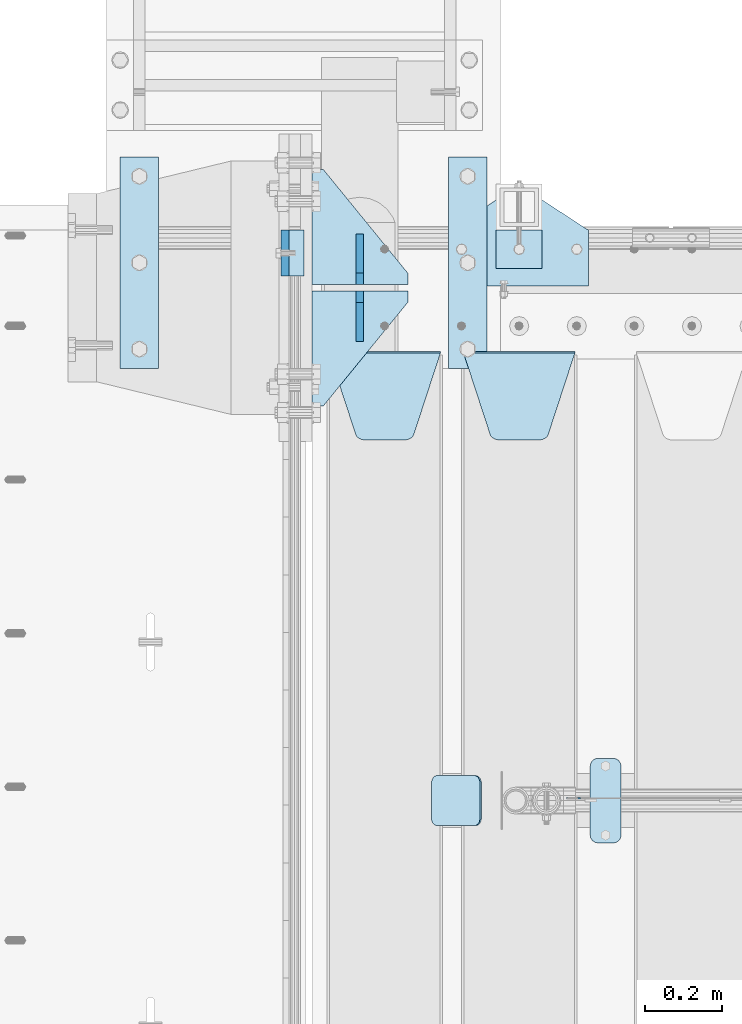
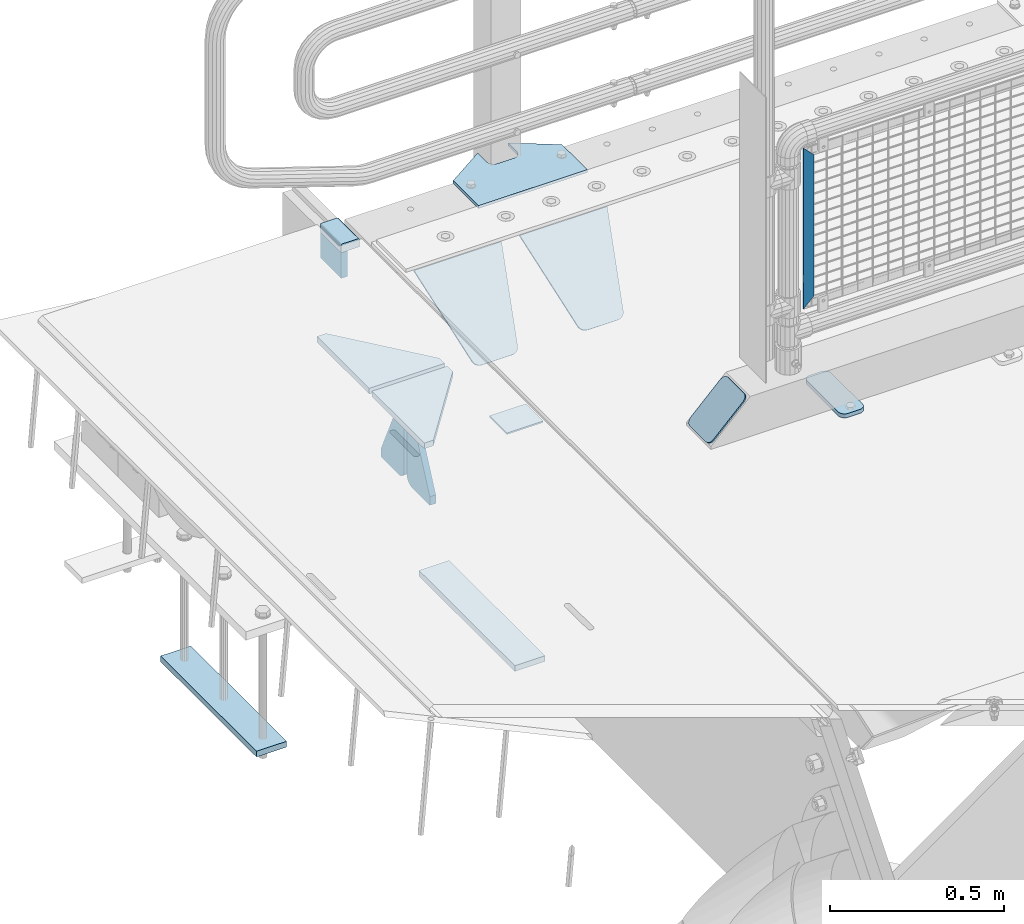
# One storey, part 229 of 270: 15 plates.
"""IFC2X3 building model written with IfcOpenShell, lengths in millimetres."""

from ifc_helpers import new_model, si_unit, frame, origin_with_axes, place, context, subcontext, project, spatial, faceted_brep, material, type_object, element, save


model = new_model("IFC2X3")

# Units and contexts
model_context = context("Model", 3, precision=1e-05, world=origin_with_axes())
body_context = subcontext(model_context, "Body", "Model", "MODEL_VIEW")
ifc_project = project(units=[si_unit("LENGTHUNIT", "METRE", prefix="MILLI"), si_unit("AREAUNIT", "SQUARE_METRE"), si_unit("VOLUMEUNIT", "CUBIC_METRE"), si_unit("MASSUNIT", "GRAM", prefix="KILO"), si_unit("TIMEUNIT", "SECOND"), si_unit("PLANEANGLEUNIT", "RADIAN"), si_unit("SOLIDANGLEUNIT", "STERADIAN"), si_unit("THERMODYNAMICTEMPERATUREUNIT", "DEGREE_CELSIUS"), si_unit("LUMINOUSINTENSITYUNIT", "LUMEN")], contexts=[model_context])

# Site, building, storey
site_placement = place(None, origin_with_axes())
site = spatial("IfcSite", under=ifc_project, at=site_placement, CompositionType="ELEMENT")
building_placement = place(site_placement, origin_with_axes())
building = spatial("IfcBuilding", under=site, at=building_placement, Name="Standard", CompositionType="ELEMENT")
storey_placement = place(building_placement, origin_with_axes())
storey = spatial("IfcBuildingStorey", under=building, at=storey_placement, Name="Undefined", CompositionType="ELEMENT", Elevation=0.0)

# Plates
ifc_material_1 = material()
plate_type_1 = type_object("IfcPlateType", PredefinedType="NOTDEFINED")
plate_1_placement = place(storey_placement, frame((-9.99999999999636, -14910.0, -16.0000571412578), z_axis=(-1.0, 0.0, 0.0), x_axis=(0.0, 0.0, 1.0)))
element("IfcPlate", 1, at=plate_1_placement, inside=storey, type_object=plate_type_1, material=ifc_material_1, context=body_context, shape_type="Brep", body=[
    faceted_brep([(1.77635683940025e-15, -60.0000000000073, 0.0), (2.49929321682885e-09, -60.0000000000073, 60.0), (2.49928966411517e-09, 59.9999999999964, 60.0), (-1.77635683940025e-15, 59.9999999999964, 0.0), (25.0146748218828, -60.0000000000073, 60.0), (25.0146748218828, 59.9999999999927, 60.0), (26.5597449794466, -60.0000000000073, 59.7552873949117), (26.5597449794466, 59.9999999999964, 59.7552873949117), (27.9535758796897, -60.0000000000036, 59.0451032832824), (27.9535758796897, 59.9999999999964, 59.0451032832824), (29.0597323263517, -60.0000000000073, 57.9389640667317), (29.0597323263517, 59.9999999999927, 57.9389640667317), (29.7699381491534, -60.0000000000036, 56.5451442289687), (29.7699381491534, 59.9999999999927, 56.5451442289687), (30.0146748212763, -60.0000000000073, 55.0000778834025), (30.0146748212762, 59.9999999999927, 55.0000778834025), (30.0154536553013, -60.0000000000036, 5.00007788340855), (30.0154536553013, 59.9999999999964, 5.00007788340855), (29.7707554908505, -60.0000000000073, 3.45497428546548), (29.7707554908505, 59.9999999999927, 3.45497428546548), (29.0605660948355, -60.0000000000073, 2.06111154407017), (29.0605660948355, 59.9999999999927, 2.06111154407017), (27.9544051209123, -60.0000000000036, 0.954933339696428), (27.9544051209123, 59.9999999999964, 0.954933339696428), (26.5605534420796, -60.0000000000036, 0.244722232012666), (26.5605534420796, 59.9999999999964, 0.244722232012666), (25.0154536559091, -60.0000000000073, 6.05382410867605e-12), (25.0154536559091, 59.9999999999927, 6.05382410867605e-12)], [[[0, 1, 2, 3]], [[1, 4, 5, 2]], [[4, 6, 7, 5]], [[6, 8, 9, 7]], [[8, 10, 11, 9]], [[10, 12, 13, 11]], [[12, 14, 15, 13]], [[14, 16, 17, 15]], [[16, 18, 19, 17]], [[18, 20, 21, 19]], [[20, 22, 23, 21]], [[22, 24, 25, 23]], [[24, 26, 27, 25]], [[26, 0, 3, 27]], [[5, 7, 9, 11, 13, 15, 17, 19, 21, 23, 25, 27, 3, 2]], [[26, 24, 22, 20, 18, 16, 14, 12, 10, 8, 6, 4, 1, 0]]]),
])
ifc_material_2 = material(Name="STEEL/S355N")
plate_type_2 = type_object("IfcPlateType", PredefinedType="NOTDEFINED")
plate_2_placement = place(storey_placement, frame((-60.0, -14849.9999144655, -105.984391681369), z_axis=(0.0, -1.0, 0.0), x_axis=(0.0, 0.0, 1.0)))
element("IfcPlate", 2, at=plate_2_placement, inside=storey, type_object=plate_type_2, material=ifc_material_2, context=body_context, shape_type="Brep", body=[
    faceted_brep([(0.0, -10.0, 0.0), (4.30830482400779e-10, -10.0, 120.000000000004), (4.30830482400779e-10, 10.0, 120.000000000004), (0.0, 10.0, 0.0), (89.9845046997066, -10.0, 120.0), (89.9845046997066, 10.0, 120.0), (89.9843902587891, -10.0, 6.54836185276508e-11), (89.9843902587891, 10.0, 6.54836185276508e-11)], [[[0, 1, 2, 3]], [[1, 4, 5, 2]], [[4, 6, 7, 5]], [[6, 0, 3, 7]], [[5, 7, 3, 2]], [[6, 4, 1, 0]]]),
])
plate_type_3 = type_object("IfcPlateType", PredefinedType="NOTDEFINED")
for number, where, z_axis, x_axis in (
    (3, (-488.999999999984, -14660.0000007156, -1478.0), (0.0, -1.0, 0.0), (1.0, 0.0, 0.0)),
    (4, (366.000000000016, -14659.9999998606, -1478.0), (0.0, -1.0, 0.0), (1.0, 0.0, 0.0)),
):
    element("IfcPlate", number, at=place(storey_placement, frame(where, z_axis=z_axis, x_axis=x_axis)), inside=storey, type_object=plate_type_3, material=ifc_material_2, context=body_context, shape_type="Brep", body=[
        faceted_brep([(0.0, -10.0, 0.0), (1.00943600500614e-06, -10.0, 550.0), (1.00943600500614e-06, 10.0, 550.0), (0.0, 10.0, 0.0), (100.000000000004, -10.0, 550.0), (100.000000000004, 10.0, 550.0), (100.0, -10.0, 0.0), (100.0, 10.0, 0.0)], [[[0, 1, 2, 3]], [[1, 4, 5, 2]], [[4, 6, 7, 5]], [[6, 0, 3, 7]], [[5, 7, 3, 2]], [[6, 4, 1, 0]]]),
    ])
ifc_material_3 = material(Name="STEEL/S355J2")
plate_type_4 = type_object("IfcPlateType", PredefinedType="NOTDEFINED")
plate_3_placement = place(storey_placement, frame((370.0, -14995.0, 5.00000000004911), z_axis=(0.0, 1.0, 0.0), x_axis=(1.0, 0.0, 0.0)))
element("IfcPlate", 5, at=plate_3_placement, inside=storey, type_object=plate_type_4, material=ifc_material_3, context=body_context, shape_type="Brep", body=[
    faceted_brep([(0.0, -5.0, 0.0), (2.31396552408114e-06, -5.0, 145.0), (2.31396552408114e-06, 5.0, 145.0), (0.0, 5.0, 0.0), (130.0, -5.0, 230.0), (130.0, 5.0, 230.0), (130.0, -5.0, 180.0), (130.0, 5.0, 180.0), (130.48036798992, -5.0, 175.122741949597), (130.48036798992, 5.0, 175.122741949597), (131.903011687216, -5.0, 170.432914190873), (131.903011687216, 5.0, 170.432914190873), (134.213259692435, -5.0, 166.11074417451), (134.213259692435, 5.0, 166.11074417451), (137.322330470335, -5.0, 162.322330470337), (137.322330470335, 5.0, 162.322330470337), (141.110744174512, -5.0, 159.213259692437), (141.110744174512, 5.0, 159.213259692437), (145.432914190871, -5.0, 156.903011687218), (145.432914190871, 5.0, 156.903011687218), (150.122741949595, -5.0, 155.48036798992), (150.122741949595, 5.0, 155.48036798992), (155.0, -5.0, 155.0), (155.0, 5.0, 155.0), (205.0, -5.0, 155.0), (205.0, 5.0, 155.0), (209.877258050405, -5.0, 155.48036798992), (209.877258050405, 5.0, 155.48036798992), (214.567085809129, -5.0, 156.903011687218), (214.567085809129, 5.0, 156.903011687218), (218.889255825488, -5.0, 159.213259692437), (218.889255825488, 5.0, 159.213259692437), (222.677669529665, -5.0, 162.322330470337), (222.677669529665, 5.0, 162.322330470337), (225.786740307565, -5.0, 166.11074417451), (225.786740307565, 5.0, 166.11074417451), (228.096988312784, -5.0, 170.432914190873), (228.096988312784, 5.0, 170.432914190873), (229.51963201008, -5.0, 175.122741949597), (229.51963201008, 5.0, 175.122741949597), (230.0, -5.0, 180.0), (230.0, 5.0, 180.0), (230.0, -5.0, 230.0), (230.0, 5.0, 230.0), (360.0, -5.0, 145.0), (360.0, 5.0, 145.0), (360.0, -5.0, -7.27595761418343e-12), (360.0, 5.0, -7.27595761418343e-12)], [[[0, 1, 2, 3]], [[1, 4, 5, 2]], [[4, 6, 7, 5]], [[6, 8, 9, 7]], [[8, 10, 11, 9]], [[10, 12, 13, 11]], [[12, 14, 15, 13]], [[14, 16, 17, 15]], [[16, 18, 19, 17]], [[18, 20, 21, 19]], [[20, 22, 23, 21]], [[22, 24, 25, 23]], [[24, 26, 27, 25]], [[26, 28, 29, 27]], [[28, 30, 31, 29]], [[30, 32, 33, 31]], [[32, 34, 35, 33]], [[34, 36, 37, 35]], [[36, 38, 39, 37]], [[38, 40, 41, 39]], [[40, 42, 43, 41]], [[42, 44, 45, 43]], [[44, 46, 47, 45]], [[46, 0, 3, 47]], [[5, 7, 9, 11, 13, 15, 17, 19, 21, 23, 25, 27, 29, 31, 33, 35, 37, 39, 41, 43, 45, 47, 3, 2]], [[46, 44, 42, 40, 38, 36, 34, 32, 30, 28, 26, 24, 22, 20, 18, 16, 14, 12, 10, 8, 6, 4, 1, 0]]]),
])
plate_type_5 = type_object("IfcPlateType", PredefinedType="NOTDEFINED")
plate_4_placement = place(storey_placement, frame((490.000000000138, -14949.9999999998, -857.500000000002), z_axis=(0.0, 1.0, 0.0), x_axis=(1.0, 0.0, 0.0)))
element("IfcPlate", 6, at=plate_4_placement, inside=storey, type_object=plate_type_5, material=ifc_material_3, context=body_context, shape_type="Brep", body=[
    faceted_brep([(0.0, -2.5, 0.0), (0.0, -2.5, 100.0), (0.0, 2.5, 100.0), (0.0, 2.5, 0.0), (120.0, -2.5, 100.0), (120.0, 2.5, 100.0), (120.0, -2.5, 0.0), (120.0, 2.5, 0.0)], [[[0, 1, 2, 3]], [[1, 4, 5, 2]], [[4, 6, 7, 5]], [[6, 0, 3, 7]], [[5, 7, 3, 2]], [[6, 4, 1, 0]]]),
])
plate_type_6 = type_object("IfcPlateType", PredefinedType="NOTDEFINED")
plate_5_placement = place(storey_placement, frame((735.0, -16225.5, 21.0199999999977), z_axis=(1.0, 0.0, 0.0), x_axis=(0.0, -1.0, 0.0)))
element("IfcPlate", 7, at=plate_5_placement, inside=storey, type_object=plate_type_6, material=ifc_material_3, context=body_context, shape_type="Brep", body=[
    faceted_brep([(0.0, -7.0, 20.0), (0.0, -7.0, 60.0), (0.0, 7.0, 60.0), (0.0, 7.0, 20.0), (0.384294391937146, -7.0, 63.9018064403208), (0.384294391937146, 7.0, 63.9018064403208), (1.52240934977453, -7.0, 67.6536686473009), (1.52240934977453, 7.0, 67.6536686473009), (3.37060775395003, -7.0, 71.1114046603907), (3.37060775395003, 7.0, 71.1114046603907), (5.8578643762703, -7.0, 74.1421356237297), (5.8578643762703, 7.0, 74.1421356237297), (8.88859533960931, -7.0, 76.62939224605), (8.88859533960931, 7.0, 76.62939224605), (12.3463313526991, -7.0, 78.4775906502255), (12.3463313526991, 7.0, 78.4775906502255), (16.0981935596792, -7.0, 79.6157056080629), (16.0981935596792, 7.0, 79.6157056080629), (20.0, -7.0, 80.0), (20.0, 7.0, 80.0), (200.0, -7.0, 80.0), (200.0, 7.0, 80.0), (203.901806440321, -7.0, 79.6157056080629), (203.901806440321, 7.0, 79.6157056080629), (207.653668647301, -7.0, 78.4775906502255), (207.653668647301, 7.0, 78.4775906502255), (211.111404660391, -7.0, 76.62939224605), (211.111404660391, 7.0, 76.62939224605), (214.142135623733, -7.0, 74.1421356237297), (214.142135623733, 7.0, 74.1421356237297), (216.629392246054, -7.0, 71.1114046603907), (216.629392246054, 7.0, 71.1114046603907), (218.477590650225, -7.0, 67.6536686473009), (218.477590650225, 7.0, 67.6536686473009), (219.615705608063, -7.0, 63.9018064403208), (219.615705608063, 7.0, 63.9018064403208), (220.0, -7.0, 60.0), (220.0, 7.0, 60.0), (220.0, -7.0, 20.0), (220.0, 7.0, 20.0), (219.615705608063, -7.0, 16.0981935596792), (219.615705608063, 7.0, 16.0981935596792), (218.477590650225, -7.0, 12.3463313526991), (218.477590650225, 7.0, 12.3463313526991), (216.629392246054, -7.0, 8.88859533960931), (216.629392246054, 7.0, 8.88859533960931), (214.142135623733, -7.0, 5.8578643762703), (214.142135623733, 7.0, 5.8578643762703), (211.111404660391, -7.0, 3.37060775395003), (211.111404660391, 7.0, 3.37060775395003), (207.653668647301, -7.0, 1.52240934977453), (207.653668647301, 7.0, 1.52240934977453), (203.901806440321, -7.0, 0.384294391937146), (203.901806440321, 7.0, 0.384294391937146), (200.0, -7.0, 0.0), (200.0, 7.0, 0.0), (20.0, -7.0, 0.0), (20.0, 7.0, 0.0), (16.0981935596792, -7.0, 0.384294391937146), (16.0981935596792, 7.0, 0.384294391937146), (12.3463313526991, -7.0, 1.52240934977453), (12.3463313526991, 7.0, 1.52240934977453), (8.88859533960931, -7.0, 3.37060775395003), (8.88859533960931, 7.0, 3.37060775395003), (5.8578643762703, -7.0, 5.8578643762703), (5.8578643762703, 7.0, 5.8578643762703), (3.37060775395003, -7.0, 8.88859533960931), (3.37060775395003, 7.0, 8.88859533960931), (1.52240934977453, -7.0, 12.3463313526991), (1.52240934977453, 7.0, 12.3463313526991), (0.384294391937146, -7.0, 16.0981935596792), (0.384294391937146, 7.0, 16.0981935596792)], [[[0, 1, 2, 3]], [[1, 4, 5, 2]], [[4, 6, 7, 5]], [[6, 8, 9, 7]], [[8, 10, 11, 9]], [[10, 12, 13, 11]], [[12, 14, 15, 13]], [[14, 16, 17, 15]], [[16, 18, 19, 17]], [[18, 20, 21, 19]], [[20, 22, 23, 21]], [[22, 24, 25, 23]], [[24, 26, 27, 25]], [[26, 28, 29, 27]], [[28, 30, 31, 29]], [[30, 32, 33, 31]], [[32, 34, 35, 33]], [[34, 36, 37, 35]], [[36, 38, 39, 37]], [[38, 40, 41, 39]], [[40, 42, 43, 41]], [[42, 44, 45, 43]], [[44, 46, 47, 45]], [[46, 48, 49, 47]], [[48, 50, 51, 49]], [[50, 52, 53, 51]], [[52, 54, 55, 53]], [[54, 56, 57, 55]], [[56, 58, 59, 57]], [[58, 60, 61, 59]], [[60, 62, 63, 61]], [[62, 64, 65, 63]], [[64, 66, 67, 65]], [[66, 68, 69, 67]], [[68, 70, 71, 69]], [[70, 0, 3, 71]], [[5, 7, 9, 11, 13, 15, 17, 19, 21, 23, 25, 27, 29, 31, 33, 35, 37, 39, 41, 43, 45, 47, 49, 51, 53, 55, 57, 59, 61, 63, 65, 67, 69, 71, 3, 2]], [[70, 68, 66, 64, 62, 60, 58, 56, 54, 52, 50, 48, 46, 44, 42, 40, 38, 36, 34, 32, 30, 28, 26, 24, 22, 20, 18, 16, 14, 12, 10, 8, 6, 4, 1, 0]]]),
])
plate_type_7 = type_object("IfcPlateType", PredefinedType="NOTDEFINED")
plate_6_placement = place(storey_placement, frame((405.0, -15168.2322330441, -1.76776695296576), z_axis=(0.0, -0.707106781186548, -0.707106781186547), x_axis=(1.0, 0.0, 0.0)))
element("IfcPlate", 8, at=plate_6_placement, inside=storey, type_object=plate_type_7, material=ifc_material_2, context=body_context, shape_type="Brep", body=[
    faceted_brep([(0.0, -2.5, 0.0), (69.345504679477, -2.5, 300.171731424831), (69.345504679477, 2.5, 300.171731424831), (0.0, 2.5, 0.0), (70.9274061199576, -2.5, 304.8974424154), (70.9274061199576, 2.5, 304.8974424154), (73.3818627772307, -2.49999999999818, 309.234538108527), (73.3818627772307, 2.50000000000182, 309.234538108527), (76.6187032999551, -2.5, 313.023683126103), (76.6187032999551, 2.5, 313.023683126103), (80.5190132704993, -2.5, 316.125672595372), (80.5190132704993, 2.50000000000182, 316.125672595372), (84.9395038596849, -2.49999999999818, 318.426546230476), (84.9395038596849, 2.5, 318.426546230476), (89.7177759439219, -2.49999999999818, 319.841774983275), (89.7177759439219, 2.50000000000182, 319.841774983275), (94.678286292652, -2.5, 320.319366455078), (94.678286292652, 2.5, 320.319366455078), (195.321713707348, -2.5, 320.319366455078), (195.321713707348, 2.5, 320.319366455078), (200.282224056078, -2.49999999999818, 319.841774983275), (200.282224056078, 2.50000000000182, 319.841774983275), (205.060496140315, -2.5, 318.426546230476), (205.060496140315, 2.5, 318.426546230476), (209.480986729501, -2.5, 316.12567259537), (209.480986729501, 2.50000000000182, 316.12567259537), (213.381296700045, -2.5, 313.023683126103), (213.381296700045, 2.5, 313.023683126103), (216.618137222769, -2.49999999999818, 309.234538108525), (216.618137222769, 2.50000000000182, 309.234538108527), (219.072593880042, -2.49999999999818, 304.897442415398), (219.072593880042, 2.50000000000182, 304.897442415397), (220.654495320523, -2.5, 300.171731424831), (220.654495320523, 2.5, 300.171731424831), (290.0, -2.49999999999818, 0.0), (290.0, 2.5, 0.0)], [[[0, 1, 2, 3]], [[1, 4, 5, 2]], [[4, 6, 7, 5]], [[6, 8, 9, 7]], [[8, 10, 11, 9]], [[10, 12, 13, 11]], [[12, 14, 15, 13]], [[14, 16, 17, 15]], [[16, 18, 19, 17]], [[18, 20, 21, 19]], [[20, 22, 23, 21]], [[22, 24, 25, 23]], [[24, 26, 27, 25]], [[26, 28, 29, 27]], [[28, 30, 31, 29]], [[30, 32, 33, 31]], [[32, 34, 35, 33]], [[34, 0, 3, 35]], [[5, 7, 9, 11, 13, 15, 17, 19, 21, 23, 25, 27, 29, 31, 33, 35, 3, 2]], [[34, 32, 30, 28, 26, 24, 22, 20, 18, 16, 14, 12, 10, 8, 6, 4, 1, 0]]]),
])
plate_7_placement = place(storey_placement, frame((55.0, -15168.2322330441, -1.76776695296576), z_axis=(0.0, -0.707106781186548, -0.707106781186547), x_axis=(1.0, 0.0, 0.0)))
element("IfcPlate", 9, at=plate_7_placement, inside=storey, type_object=plate_type_7, material=ifc_material_2, context=body_context, shape_type="Brep", body=[
    faceted_brep([(0.0, -2.5, 0.0), (69.345504679477, -2.5, 300.171731424831), (69.345504679477, 2.5, 300.171731424831), (0.0, 2.5, 0.0), (70.9274061199576, -2.5, 304.8974424154), (70.9274061199576, 2.5, 304.8974424154), (73.3818627772307, -2.49999999999818, 309.234538108527), (73.3818627772307, 2.50000000000182, 309.234538108527), (76.6187032999551, -2.5, 313.023683126103), (76.6187032999551, 2.5, 313.023683126103), (80.5190132704993, -2.5, 316.125672595372), (80.5190132704993, 2.50000000000182, 316.125672595372), (84.9395038596849, -2.49999999999818, 318.426546230476), (84.9395038596849, 2.5, 318.426546230476), (89.7177759439219, -2.49999999999818, 319.841774983275), (89.7177759439219, 2.50000000000182, 319.841774983275), (94.678286292652, -2.5, 320.319366455078), (94.678286292652, 2.5, 320.319366455078), (195.321713707348, -2.5, 320.319366455078), (195.321713707348, 2.5, 320.319366455078), (200.282224056078, -2.49999999999818, 319.841774983275), (200.282224056078, 2.50000000000182, 319.841774983275), (205.060496140315, -2.5, 318.426546230476), (205.060496140315, 2.5, 318.426546230476), (209.480986729501, -2.5, 316.12567259537), (209.480986729501, 2.50000000000182, 316.12567259537), (213.381296700045, -2.5, 313.023683126103), (213.381296700045, 2.5, 313.023683126103), (216.618137222769, -2.49999999999818, 309.234538108525), (216.618137222769, 2.50000000000182, 309.234538108527), (219.072593880042, -2.49999999999818, 304.897442415398), (219.072593880042, 2.50000000000182, 304.897442415397), (220.654495320523, -2.5, 300.171731424831), (220.654495320523, 2.5, 300.171731424831), (290.0, -2.49999999999818, 0.0), (290.0, 2.5, 0.0)], [[[0, 1, 2, 3]], [[1, 4, 5, 2]], [[4, 6, 7, 5]], [[6, 8, 9, 7]], [[8, 10, 11, 9]], [[10, 12, 13, 11]], [[12, 14, 15, 13]], [[14, 16, 17, 15]], [[16, 18, 19, 17]], [[18, 20, 21, 19]], [[20, 22, 23, 21]], [[22, 24, 25, 23]], [[24, 26, 27, 25]], [[26, 28, 29, 27]], [[28, 30, 31, 29]], [[30, 32, 33, 31]], [[32, 34, 35, 33]], [[34, 0, 3, 35]], [[5, 7, 9, 11, 13, 15, 17, 19, 21, 23, 25, 27, 29, 31, 33, 35, 3, 2]], [[34, 32, 30, 28, 26, 24, 22, 20, 18, 16, 14, 12, 10, 8, 6, 4, 1, 0]]]),
])
ifc_material_4 = material(Name="Misc_Undefined")
plate_type_8 = type_object("IfcPlateType", PredefinedType="NOTDEFINED")
plate_8_placement = place(storey_placement, frame((709.509713540967, -16329.5, 879.519963133601), z_axis=(-0.707008801899319, 0.0, -0.707204746899291), x_axis=(-0.707204746899302, 0.0, 0.707008801899308)))
element("IfcPlate", 10, at=plate_8_placement, inside=storey, type_object=plate_type_8, material=ifc_material_4, context=body_context, shape_type="Brep", body=[
    faceted_brep([(0.0, -1.5, 0.0), (-348.552185058599, -1.5, 348.655029296877), (-348.552185058599, 1.5, 348.655029296877), (0.0, 1.5, 0.0), (-348.544891357427, -1.5, 398.152496337894), (-348.544891357427, 1.5, 398.152496337894), (49.50439453125, -1.5, 8.00355337560177e-11), (49.50439453125, 1.5, 8.00355337560177e-11)], [[[0, 1, 2, 3]], [[1, 4, 5, 2]], [[4, 6, 7, 5]], [[6, 0, 3, 7]], [[5, 7, 3, 2]], [[6, 4, 1, 0]]]),
])
plate_type_9 = type_object("IfcPlateType", PredefinedType="NOTDEFINED")
for number, where, z_axis, x_axis in (
    (11, (259.999999999999, -15008.0, -515.0), (0.0, -1.0, 0.0), (-1.0, 0.0, 0.0)),
    (12, (260.0, -14992.0, -515.0), (0.0, 1.0, 0.0), (-1.0, 0.0, 0.0)),
):
    element("IfcPlate", number, at=place(storey_placement, frame(where, z_axis=z_axis, x_axis=x_axis)), inside=storey, type_object=plate_type_9, material=ifc_material_2, context=body_context, shape_type="Brep", body=[
        faceted_brep([(0.0, -10.0, 0.0), (0.0, -10.0, 30.0), (0.0, 10.0, 30.0), (0.0, 10.0, 0.0), (220.0, -10.0, 300.0), (220.0, 10.0, 300.0), (250.0, -10.0, 300.0), (250.0, 10.0, 300.0), (250.0, -10.0, 0.0), (250.0, 10.0, 0.0)], [[[0, 1, 2, 3]], [[1, 4, 5, 2]], [[4, 6, 7, 5]], [[6, 8, 9, 7]], [[8, 0, 3, 9]], [[5, 7, 9, 3, 2]], [[8, 6, 4, 1, 0]]]),
    ])
plate_type_10 = type_object("IfcPlateType", PredefinedType="NOTDEFINED")
for number, where, z_axis, x_axis in (
    (13, (135.000000000004, -15140.0, -865.0), (0.0, 0.0, 1.0), (0.0, 1.0, 0.0)),
    (14, (135.000000000004, -14860.0, -865.0), (0.0, 0.0, 1.0), (0.0, -1.0, 0.0)),
):
    element("IfcPlate", number, at=place(storey_placement, frame(where, z_axis=z_axis, x_axis=x_axis)), inside=storey, type_object=plate_type_10, material=ifc_material_2, context=body_context, shape_type="Brep", body=[
        faceted_brep([(0.0, -10.0, 0.0), (0.0, -10.0, 30.0), (0.0, 10.0, 30.0), (0.0, 10.0, 0.0), (102.0, -10.0, 250.0), (102.0, 10.0, 250.0), (132.0, -10.0, 250.0), (132.0, 10.0, 250.0), (132.0, -10.0, 30.0), (132.0, 10.0, 30.0), (131.544232590368, -10.0, 24.790554669992), (131.544232590368, 10.0, 24.790554669992), (130.190778623579, -10.0, 19.7393957002299), (130.190778623579, 10.0, 19.7393957002299), (127.980762113533, -10.0, 15.0), (127.980762113533, 10.0, 15.0), (124.98133329357, -10.0, 10.7163717094038), (124.98133329357, 10.0, 10.7163717094038), (121.283628290596, -10.0, 7.01866670643062), (121.283628290596, 10.0, 7.01866670643062), (117.0, -10.0, 4.01923788646684), (117.0, 10.0, 4.01923788646684), (112.260604299769, -10.0, 1.80922137642278), (112.260604299769, 10.0, 1.80922137642278), (107.209445330009, -10.0, 0.455767409633722), (107.209445330009, 10.0, 0.455767409633722), (102.0, -10.0, 0.0), (102.0, 10.0, 0.0)], [[[0, 1, 2, 3]], [[1, 4, 5, 2]], [[4, 6, 7, 5]], [[6, 8, 9, 7]], [[8, 10, 11, 9]], [[10, 12, 13, 11]], [[12, 14, 15, 13]], [[14, 16, 17, 15]], [[16, 18, 19, 17]], [[18, 20, 21, 19]], [[20, 22, 23, 21]], [[22, 24, 25, 23]], [[24, 26, 27, 25]], [[26, 0, 3, 27]], [[5, 7, 9, 11, 13, 15, 17, 19, 21, 23, 25, 27, 3, 2]], [[26, 24, 22, 20, 18, 16, 14, 12, 10, 8, 6, 4, 1, 0]]]),
    ])
plate_type_11 = type_object("IfcPlateType", PredefinedType="NOTDEFINED")
plate_9_placement = place(storey_placement, frame((449.80758152104, -16270.5, 166.254400376568), z_axis=(-0.707410512925777, 0.0, -0.706802918925841), x_axis=(0.0, -1.0, 0.0)))
element("IfcPlate", 15, at=plate_9_placement, inside=storey, type_object=plate_type_11, material=ifc_material_3, context=body_context, shape_type="Brep", body=[
    faceted_brep([(0.0, -2.50000000000182, 20.0), (0.0, -2.50000000000182, 158.926651000977), (0.0, 2.49999999999818, 158.926651000977), (0.0, 2.49999999999818, 20.0), (0.384294391935327, -2.5, 162.828457441299), (0.384294391935327, 2.49999999999818, 162.828457441301), (1.52240934977453, -2.5, 166.580319648279), (1.52240934977453, 2.49999999999818, 166.580319648278), (3.37060775394821, -2.5, 170.038055661367), (3.37060775394821, 2.49999999999818, 170.038055661369), (5.85786437626848, -2.5, 173.068786624706), (5.85786437626848, 2.49999999999818, 173.068786624708), (8.88859533960749, -2.50000000000182, 175.556043247028), (8.88859533960749, 2.49999999999818, 175.556043247028), (12.3463313526991, -2.50000000000182, 177.404241651202), (12.3463313526991, 2.5, 177.404241651202), (16.0981935596774, -2.50000000000182, 178.542356609043), (16.0981935596774, 2.5, 178.542356609041), (20.0, -2.5, 178.926651000975), (20.0, 2.49999999999818, 178.926651000977), (110.0, -2.5, 178.926651000975), (110.0, 2.49999999999818, 178.926651000977), (113.901806440321, -2.50000000000182, 178.542356609043), (113.901806440321, 2.5, 178.542356609041), (117.653668647301, -2.50000000000182, 177.404241651202), (117.653668647301, 2.5, 177.404241651202), (121.111404660391, -2.50000000000182, 175.556043247028), (121.111404660391, 2.49999999999818, 175.556043247028), (124.14213562373, -2.5, 173.068786624706), (124.14213562373, 2.49999999999818, 173.068786624708), (126.62939224605, -2.5, 170.038055661367), (126.62939224605, 2.49999999999818, 170.038055661369), (128.477590650225, -2.5, 166.580319648279), (128.477590650225, 2.49999999999818, 166.580319648278), (129.615705608063, -2.5, 162.828457441299), (129.615705608063, 2.49999999999818, 162.828457441301), (130.0, -2.50000000000182, 158.926651000977), (130.0, 2.49999999999818, 158.926651000977), (130.0, -2.50000000000182, 20.0), (130.0, 2.49999999999818, 20.0), (129.615705608063, -2.50000000000182, 16.0981935596792), (129.615705608063, 2.49999999999818, 16.0981935596792), (128.477590650225, -2.5, 12.3463313526991), (128.477590650225, 2.49999999999818, 12.3463313526991), (126.62939224605, -2.5, 8.88859533960749), (126.62939224605, 2.49999999999818, 8.88859533960931), (124.14213562373, -2.50000000000182, 5.8578643762703), (124.14213562373, 2.49999999999818, 5.8578643762703), (121.111404660391, -2.50000000000182, 3.37060775394821), (121.111404660391, 2.5, 3.37060775394821), (117.653668647301, -2.50000000000182, 1.52240934977453), (117.653668647301, 2.49999999999818, 1.52240934977635), (113.901806440321, -2.5, 0.384294391935327), (113.901806440321, 2.5, 0.384294391935327), (110.0, -2.50000000000182, 1.81898940354586e-12), (110.0, 2.5, -1.81898940354586e-12), (20.0, -2.50000000000182, 1.81898940354586e-12), (20.0, 2.5, -1.81898940354586e-12), (16.0981935596774, -2.5, 0.384294391935327), (16.0981935596774, 2.5, 0.384294391935327), (12.3463313526991, -2.50000000000182, 1.52240934977453), (12.3463313526991, 2.49999999999818, 1.52240934977635), (8.88859533960749, -2.50000000000182, 3.37060775394821), (8.88859533960749, 2.5, 3.37060775394821), (5.85786437626848, -2.50000000000182, 5.8578643762703), (5.85786437626848, 2.49999999999818, 5.8578643762703), (3.37060775394821, -2.5, 8.88859533960749), (3.37060775394821, 2.49999999999818, 8.88859533960931), (1.52240934977453, -2.5, 12.3463313526991), (1.52240934977453, 2.49999999999818, 12.3463313526991), (0.384294391935327, -2.50000000000182, 16.0981935596792), (0.384294391935327, 2.49999999999818, 16.0981935596792)], [[[0, 1, 2, 3]], [[1, 4, 5, 2]], [[4, 6, 7, 5]], [[6, 8, 9, 7]], [[8, 10, 11, 9]], [[10, 12, 13, 11]], [[12, 14, 15, 13]], [[14, 16, 17, 15]], [[16, 18, 19, 17]], [[18, 20, 21, 19]], [[20, 22, 23, 21]], [[22, 24, 25, 23]], [[24, 26, 27, 25]], [[26, 28, 29, 27]], [[28, 30, 31, 29]], [[30, 32, 33, 31]], [[32, 34, 35, 33]], [[34, 36, 37, 35]], [[36, 38, 39, 37]], [[38, 40, 41, 39]], [[40, 42, 43, 41]], [[42, 44, 45, 43]], [[44, 46, 47, 45]], [[46, 48, 49, 47]], [[48, 50, 51, 49]], [[50, 52, 53, 51]], [[52, 54, 55, 53]], [[54, 56, 57, 55]], [[56, 58, 59, 57]], [[58, 60, 61, 59]], [[60, 62, 63, 61]], [[62, 64, 65, 63]], [[64, 66, 67, 65]], [[66, 68, 69, 67]], [[68, 70, 71, 69]], [[70, 0, 3, 71]], [[5, 7, 9, 11, 13, 15, 17, 19, 21, 23, 25, 27, 29, 31, 33, 35, 37, 39, 41, 43, 45, 47, 49, 51, 53, 55, 57, 59, 61, 63, 65, 67, 69, 71, 3, 2]], [[70, 68, 66, 64, 62, 60, 58, 56, 54, 52, 50, 48, 46, 44, 42, 40, 38, 36, 34, 32, 30, 28, 26, 24, 22, 20, 18, 16, 14, 12, 10, 8, 6, 4, 1, 0]]]),
])

save(model, "model.ifc")
